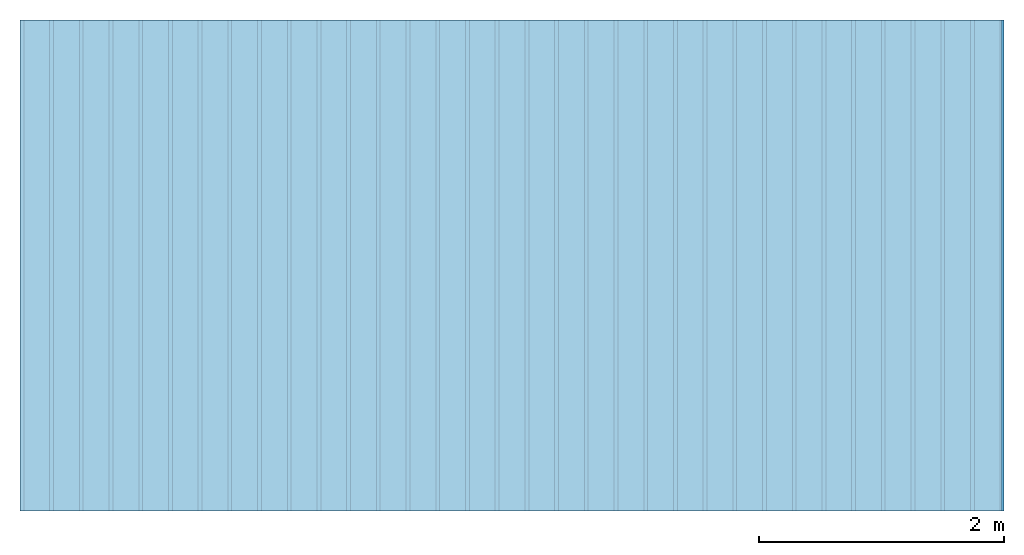
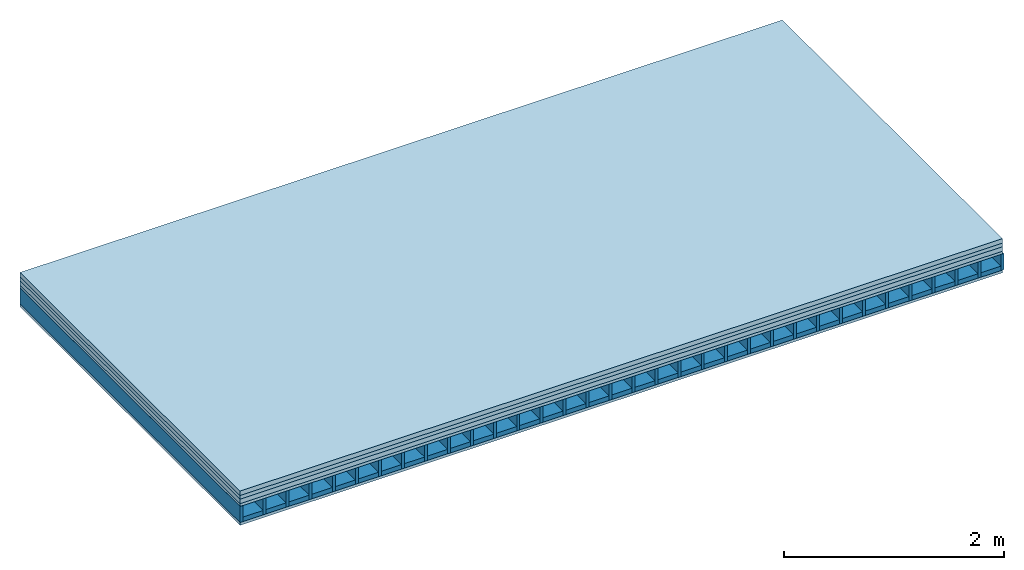
# One storey: 5 plates, 2 members, 1 element without a shape of its own.
"""IFC4 building model written with IfcOpenShell, lengths in metres."""

from ifc_helpers import new_model, si_unit, derived_unit, direction, frame, frame_2d, origin, origin_with_axes, place, context, project, spatial, rectangle, extrude, material, layer, layer_set, type_object, element, aggregate, save


model = new_model("IFC4")

# Units and contexts
plan_context = context("Plan", 3, precision=1e-05, world=origin(), true_north=direction((0.0, 1.0)))
model_context = context("Model", 3, precision=1e-05, world=origin(), true_north=direction((0.0, 1.0)))
ifc_project = project(units=[si_unit("LENGTHUNIT", "METRE"), derived_unit("SOUNDPRESSUREUNIT", [(si_unit("PRESSUREUNIT", "PASCAL", prefix="MICRO"), 0)]), si_unit("ENERGYUNIT", "JOULE", prefix="MEGA"), si_unit("MASSUNIT", "GRAM", prefix="KILO"), derived_unit("THERMALTRANSMITTANCEUNIT", [(si_unit("POWERUNIT", "WATT"), 1), (si_unit("AREAUNIT", "SQUARE_METRE"), -1), (si_unit("THERMODYNAMICTEMPERATUREUNIT", "KELVIN"), -1)]), derived_unit("AREADENSITYUNIT", [(si_unit("MASSUNIT", "GRAM", prefix="KILO"), 1), (si_unit("AREAUNIT", "SQUARE_METRE"), -1)]), derived_unit("USERDEFINED", [(si_unit("ENERGYUNIT", "JOULE", prefix="MEGA"), 1), (si_unit("AREAUNIT", "SQUARE_METRE"), -1)])], contexts=[plan_context, model_context])

# Site, building, storey
site = spatial("IfcSite", under=ifc_project)
building_placement = place(None, origin())
building = spatial("IfcBuilding", under=site, at=building_placement)
storey_placement = place(building_placement, origin())
storey = spatial("IfcBuildingStorey", under=building, at=storey_placement)

# Slab, members, plates
ifc_material_1 = material(Name="Cement screed", Category="04.006")
ifc_layer_1 = layer(ifc_material_1, 0.05, Name="On-material")
ifc_material_2 = material(Name="EP1, 40/35mm")
ifc_layer_2 = layer(ifc_material_2, 0.04, Name="Impact sound insulation")
ifc_material_3 = material(Name="Garden plates", Category="02.007")
ifc_layer_3 = layer(ifc_material_3, 0.05, Name="on Supporting structure")
ifc_material_4 = material(Name="surface element sheathing above")
ifc_layer_4 = layer(ifc_material_4, 0.031, Name="Sub-floor")
ifc_layer_5 = layer(None, 0.178, Name="Supporting structure")
ifc_material_5 = material(Name="surface element sheathing below")
ifc_layer_6 = layer(ifc_material_5, 0.031, Name="Lower layer 1")
ifc_layer_set = layer_set([ifc_layer_1, ifc_layer_2, ifc_layer_3, ifc_layer_4, ifc_layer_5, ifc_layer_6])
slab_type = type_object("IfcSlabType", Name="A2703", PredefinedType="NOTDEFINED", material=ifc_layer_set)
slab_placement = place(None, frame((0.0, 0.0, 0.0), z_axis=(0.0, 0.0, -1.0), x_axis=(1.0, 0.0, 0.0)))
slab = element("IfcSlab", 1, at=slab_placement, inside=storey, type_object=slab_type, material=ifc_layer_set, Name="Slab #1")
ifc_material_6 = material(Name="surface element LFE")
member_1_placement = place(slab_placement, origin())
member_1 = element("IfcMember", 2, at=member_1_placement, material=ifc_material_6, Name="Supporting structure", context=plan_context, shape_type="SweptSolid", body=[
    extrude(rectangle(XDim=0.031, YDim=0.178, at=frame_2d((0.0155, 0.089), x_axis=(1.0, 0.0))), frame((0.0, 4.0, 0.171), z_axis=(0.0, -1.0, 0.0), x_axis=(1.0, 0.0, 0.0)), (0.0, 0.0, 1.0), 4.0),
    extrude(rectangle(XDim=0.031, YDim=0.178, at=frame_2d((0.0155, 0.089), x_axis=(1.0, 0.0))), frame((0.242, 4.0, 0.171), z_axis=(0.0, -1.0, 0.0), x_axis=(1.0, 0.0, 0.0)), (0.0, 0.0, 1.0), 4.0),
    extrude(rectangle(XDim=0.031, YDim=0.178, at=frame_2d((0.0155, 0.089), x_axis=(1.0, 0.0))), frame((0.484, 4.0, 0.171), z_axis=(0.0, -1.0, 0.0), x_axis=(1.0, 0.0, 0.0)), (0.0, 0.0, 1.0), 4.0),
    extrude(rectangle(XDim=0.031, YDim=0.178, at=frame_2d((0.0155, 0.089), x_axis=(1.0, 0.0))), frame((0.726, 4.0, 0.171), z_axis=(0.0, -1.0, 0.0), x_axis=(1.0, 0.0, 0.0)), (0.0, 0.0, 1.0), 4.0),
    extrude(rectangle(XDim=0.031, YDim=0.178, at=frame_2d((0.0155, 0.089), x_axis=(1.0, 0.0))), frame((0.968, 4.0, 0.171), z_axis=(0.0, -1.0, 0.0), x_axis=(1.0, 0.0, 0.0)), (0.0, 0.0, 1.0), 4.0),
    extrude(rectangle(XDim=0.031, YDim=0.178, at=frame_2d((0.0155, 0.089), x_axis=(1.0, 0.0))), frame((1.21, 4.0, 0.171), z_axis=(0.0, -1.0, 0.0), x_axis=(1.0, 0.0, 0.0)), (0.0, 0.0, 1.0), 4.0),
    extrude(rectangle(XDim=0.031, YDim=0.178, at=frame_2d((0.0155, 0.089), x_axis=(1.0, 0.0))), frame((1.452, 4.0, 0.171), z_axis=(0.0, -1.0, 0.0), x_axis=(1.0, 0.0, 0.0)), (0.0, 0.0, 1.0), 4.0),
    extrude(rectangle(XDim=0.031, YDim=0.178, at=frame_2d((0.0155, 0.089), x_axis=(1.0, 0.0))), frame((1.694, 4.0, 0.171), z_axis=(0.0, -1.0, 0.0), x_axis=(1.0, 0.0, 0.0)), (0.0, 0.0, 1.0), 4.0),
    extrude(rectangle(XDim=0.031, YDim=0.178, at=frame_2d((0.0155, 0.089), x_axis=(1.0, 0.0))), frame((1.936, 4.0, 0.171), z_axis=(0.0, -1.0, 0.0), x_axis=(1.0, 0.0, 0.0)), (0.0, 0.0, 1.0), 4.0),
    extrude(rectangle(XDim=0.031, YDim=0.178, at=frame_2d((0.0155, 0.089), x_axis=(1.0, 0.0))), frame((2.178, 4.0, 0.171), z_axis=(0.0, -1.0, 0.0), x_axis=(1.0, 0.0, 0.0)), (0.0, 0.0, 1.0), 4.0),
    extrude(rectangle(XDim=0.031, YDim=0.178, at=frame_2d((0.0155, 0.089), x_axis=(1.0, 0.0))), frame((2.42, 4.0, 0.171), z_axis=(0.0, -1.0, 0.0), x_axis=(1.0, 0.0, 0.0)), (0.0, 0.0, 1.0), 4.0),
    extrude(rectangle(XDim=0.031, YDim=0.178, at=frame_2d((0.0155, 0.089), x_axis=(1.0, 0.0))), frame((2.662, 4.0, 0.171), z_axis=(0.0, -1.0, 0.0), x_axis=(1.0, 0.0, 0.0)), (0.0, 0.0, 1.0), 4.0),
    extrude(rectangle(XDim=0.031, YDim=0.178, at=frame_2d((0.0155, 0.089), x_axis=(1.0, 0.0))), frame((2.904, 4.0, 0.171), z_axis=(0.0, -1.0, 0.0), x_axis=(1.0, 0.0, 0.0)), (0.0, 0.0, 1.0), 4.0),
    extrude(rectangle(XDim=0.031, YDim=0.178, at=frame_2d((0.0155, 0.089), x_axis=(1.0, 0.0))), frame((3.146, 4.0, 0.171), z_axis=(0.0, -1.0, 0.0), x_axis=(1.0, 0.0, 0.0)), (0.0, 0.0, 1.0), 4.0),
    extrude(rectangle(XDim=0.031, YDim=0.178, at=frame_2d((0.0155, 0.089), x_axis=(1.0, 0.0))), frame((3.388, 4.0, 0.171), z_axis=(0.0, -1.0, 0.0), x_axis=(1.0, 0.0, 0.0)), (0.0, 0.0, 1.0), 4.0),
    extrude(rectangle(XDim=0.031, YDim=0.178, at=frame_2d((0.0155, 0.089), x_axis=(1.0, 0.0))), frame((3.63, 4.0, 0.171), z_axis=(0.0, -1.0, 0.0), x_axis=(1.0, 0.0, 0.0)), (0.0, 0.0, 1.0), 4.0),
    extrude(rectangle(XDim=0.031, YDim=0.178, at=frame_2d((0.0155, 0.089), x_axis=(1.0, 0.0))), frame((3.872, 4.0, 0.171), z_axis=(0.0, -1.0, 0.0), x_axis=(1.0, 0.0, 0.0)), (0.0, 0.0, 1.0), 4.0),
    extrude(rectangle(XDim=0.031, YDim=0.178, at=frame_2d((0.0155, 0.089), x_axis=(1.0, 0.0))), frame((4.114, 4.0, 0.171), z_axis=(0.0, -1.0, 0.0), x_axis=(1.0, 0.0, 0.0)), (0.0, 0.0, 1.0), 4.0),
    extrude(rectangle(XDim=0.031, YDim=0.178, at=frame_2d((0.0155, 0.089), x_axis=(1.0, 0.0))), frame((4.356, 4.0, 0.171), z_axis=(0.0, -1.0, 0.0), x_axis=(1.0, 0.0, 0.0)), (0.0, 0.0, 1.0), 4.0),
    extrude(rectangle(XDim=0.031, YDim=0.178, at=frame_2d((0.0155, 0.089), x_axis=(1.0, 0.0))), frame((4.598, 4.0, 0.171), z_axis=(0.0, -1.0, 0.0), x_axis=(1.0, 0.0, 0.0)), (0.0, 0.0, 1.0), 4.0),
    extrude(rectangle(XDim=0.031, YDim=0.178, at=frame_2d((0.0155, 0.089), x_axis=(1.0, 0.0))), frame((4.84, 4.0, 0.171), z_axis=(0.0, -1.0, 0.0), x_axis=(1.0, 0.0, 0.0)), (0.0, 0.0, 1.0), 4.0),
    extrude(rectangle(XDim=0.031, YDim=0.178, at=frame_2d((0.0155, 0.089), x_axis=(1.0, 0.0))), frame((5.082, 4.0, 0.171), z_axis=(0.0, -1.0, 0.0), x_axis=(1.0, 0.0, 0.0)), (0.0, 0.0, 1.0), 4.0),
    extrude(rectangle(XDim=0.031, YDim=0.178, at=frame_2d((0.0155, 0.089), x_axis=(1.0, 0.0))), frame((5.324, 4.0, 0.171), z_axis=(0.0, -1.0, 0.0), x_axis=(1.0, 0.0, 0.0)), (0.0, 0.0, 1.0), 4.0),
    extrude(rectangle(XDim=0.031, YDim=0.178, at=frame_2d((0.0155, 0.089), x_axis=(1.0, 0.0))), frame((5.566, 4.0, 0.171), z_axis=(0.0, -1.0, 0.0), x_axis=(1.0, 0.0, 0.0)), (0.0, 0.0, 1.0), 4.0),
    extrude(rectangle(XDim=0.031, YDim=0.178, at=frame_2d((0.0155, 0.089), x_axis=(1.0, 0.0))), frame((5.808, 4.0, 0.171), z_axis=(0.0, -1.0, 0.0), x_axis=(1.0, 0.0, 0.0)), (0.0, 0.0, 1.0), 4.0),
    extrude(rectangle(XDim=0.031, YDim=0.178, at=frame_2d((0.0155, 0.089), x_axis=(1.0, 0.0))), frame((6.05, 4.0, 0.171), z_axis=(0.0, -1.0, 0.0), x_axis=(1.0, 0.0, 0.0)), (0.0, 0.0, 1.0), 4.0),
    extrude(rectangle(XDim=0.031, YDim=0.178, at=frame_2d((0.0155, 0.089), x_axis=(1.0, 0.0))), frame((6.292, 4.0, 0.171), z_axis=(0.0, -1.0, 0.0), x_axis=(1.0, 0.0, 0.0)), (0.0, 0.0, 1.0), 4.0),
    extrude(rectangle(XDim=0.031, YDim=0.178, at=frame_2d((0.0155, 0.089), x_axis=(1.0, 0.0))), frame((6.534, 4.0, 0.171), z_axis=(0.0, -1.0, 0.0), x_axis=(1.0, 0.0, 0.0)), (0.0, 0.0, 1.0), 4.0),
    extrude(rectangle(XDim=0.031, YDim=0.178, at=frame_2d((0.0155, 0.089), x_axis=(1.0, 0.0))), frame((6.776, 4.0, 0.171), z_axis=(0.0, -1.0, 0.0), x_axis=(1.0, 0.0, 0.0)), (0.0, 0.0, 1.0), 4.0),
    extrude(rectangle(XDim=0.031, YDim=0.178, at=frame_2d((0.0155, 0.089), x_axis=(1.0, 0.0))), frame((7.018, 4.0, 0.171), z_axis=(0.0, -1.0, 0.0), x_axis=(1.0, 0.0, 0.0)), (0.0, 0.0, 1.0), 4.0),
    extrude(rectangle(XDim=0.031, YDim=0.178, at=frame_2d((0.0155, 0.089), x_axis=(1.0, 0.0))), frame((7.26, 4.0, 0.171), z_axis=(0.0, -1.0, 0.0), x_axis=(1.0, 0.0, 0.0)), (0.0, 0.0, 1.0), 4.0),
    extrude(rectangle(XDim=0.031, YDim=0.178, at=frame_2d((0.0155, 0.089), x_axis=(1.0, 0.0))), frame((7.502, 4.0, 0.171), z_axis=(0.0, -1.0, 0.0), x_axis=(1.0, 0.0, 0.0)), (0.0, 0.0, 1.0), 4.0),
    extrude(rectangle(XDim=0.031, YDim=0.178, at=frame_2d((0.0155, 0.089), x_axis=(1.0, 0.0))), frame((7.744, 4.0, 0.171), z_axis=(0.0, -1.0, 0.0), x_axis=(1.0, 0.0, 0.0)), (0.0, 0.0, 1.0), 4.0),
    extrude(rectangle(XDim=0.031, YDim=0.178, at=frame_2d((0.0155, 0.089), x_axis=(1.0, 0.0))), frame((7.986, 4.0, 0.171), z_axis=(0.0, -1.0, 0.0), x_axis=(1.0, 0.0, 0.0)), (0.0, 0.0, 1.0), 4.0),
])
ifc_material_7 = material()
member_2_placement = place(slab_placement, origin())
member_2 = element("IfcMember", 3, at=member_2_placement, material=ifc_material_7, Name="in supporting structure", context=plan_context, shape_type="SweptSolid", body=[
    extrude(rectangle(XDim=0.211, YDim=0.049, at=frame_2d((0.1055, 0.0245), x_axis=(1.0, 0.0))), frame((0.031, 4.0, 0.3), z_axis=(0.0, -1.0, 0.0), x_axis=(1.0, 0.0, 0.0)), (0.0, 0.0, 1.0), 4.0),
    extrude(rectangle(XDim=0.211, YDim=0.049, at=frame_2d((0.1055, 0.0245), x_axis=(1.0, 0.0))), frame((0.273, 4.0, 0.3), z_axis=(0.0, -1.0, 0.0), x_axis=(1.0, 0.0, 0.0)), (0.0, 0.0, 1.0), 4.0),
    extrude(rectangle(XDim=0.211, YDim=0.049, at=frame_2d((0.1055, 0.0245), x_axis=(1.0, 0.0))), frame((0.515, 4.0, 0.3), z_axis=(0.0, -1.0, 0.0), x_axis=(1.0, 0.0, 0.0)), (0.0, 0.0, 1.0), 4.0),
    extrude(rectangle(XDim=0.211, YDim=0.049, at=frame_2d((0.1055, 0.0245), x_axis=(1.0, 0.0))), frame((0.757, 4.0, 0.3), z_axis=(0.0, -1.0, 0.0), x_axis=(1.0, 0.0, 0.0)), (0.0, 0.0, 1.0), 4.0),
    extrude(rectangle(XDim=0.211, YDim=0.049, at=frame_2d((0.1055, 0.0245), x_axis=(1.0, 0.0))), frame((0.999, 4.0, 0.3), z_axis=(0.0, -1.0, 0.0), x_axis=(1.0, 0.0, 0.0)), (0.0, 0.0, 1.0), 4.0),
    extrude(rectangle(XDim=0.211, YDim=0.049, at=frame_2d((0.1055, 0.0245), x_axis=(1.0, 0.0))), frame((1.241, 4.0, 0.3), z_axis=(0.0, -1.0, 0.0), x_axis=(1.0, 0.0, 0.0)), (0.0, 0.0, 1.0), 4.0),
    extrude(rectangle(XDim=0.211, YDim=0.049, at=frame_2d((0.1055, 0.0245), x_axis=(1.0, 0.0))), frame((1.483, 4.0, 0.3), z_axis=(0.0, -1.0, 0.0), x_axis=(1.0, 0.0, 0.0)), (0.0, 0.0, 1.0), 4.0),
    extrude(rectangle(XDim=0.211, YDim=0.049, at=frame_2d((0.1055, 0.0245), x_axis=(1.0, 0.0))), frame((1.725, 4.0, 0.3), z_axis=(0.0, -1.0, 0.0), x_axis=(1.0, 0.0, 0.0)), (0.0, 0.0, 1.0), 4.0),
    extrude(rectangle(XDim=0.211, YDim=0.049, at=frame_2d((0.1055, 0.0245), x_axis=(1.0, 0.0))), frame((1.967, 4.0, 0.3), z_axis=(0.0, -1.0, 0.0), x_axis=(1.0, 0.0, 0.0)), (0.0, 0.0, 1.0), 4.0),
    extrude(rectangle(XDim=0.211, YDim=0.049, at=frame_2d((0.1055, 0.0245), x_axis=(1.0, 0.0))), frame((2.209, 4.0, 0.3), z_axis=(0.0, -1.0, 0.0), x_axis=(1.0, 0.0, 0.0)), (0.0, 0.0, 1.0), 4.0),
    extrude(rectangle(XDim=0.211, YDim=0.049, at=frame_2d((0.1055, 0.0245), x_axis=(1.0, 0.0))), frame((2.451, 4.0, 0.3), z_axis=(0.0, -1.0, 0.0), x_axis=(1.0, 0.0, 0.0)), (0.0, 0.0, 1.0), 4.0),
    extrude(rectangle(XDim=0.211, YDim=0.049, at=frame_2d((0.1055, 0.0245), x_axis=(1.0, 0.0))), frame((2.693, 4.0, 0.3), z_axis=(0.0, -1.0, 0.0), x_axis=(1.0, 0.0, 0.0)), (0.0, 0.0, 1.0), 4.0),
    extrude(rectangle(XDim=0.211, YDim=0.049, at=frame_2d((0.1055, 0.0245), x_axis=(1.0, 0.0))), frame((2.935, 4.0, 0.3), z_axis=(0.0, -1.0, 0.0), x_axis=(1.0, 0.0, 0.0)), (0.0, 0.0, 1.0), 4.0),
    extrude(rectangle(XDim=0.211, YDim=0.049, at=frame_2d((0.1055, 0.0245), x_axis=(1.0, 0.0))), frame((3.177, 4.0, 0.3), z_axis=(0.0, -1.0, 0.0), x_axis=(1.0, 0.0, 0.0)), (0.0, 0.0, 1.0), 4.0),
    extrude(rectangle(XDim=0.211, YDim=0.049, at=frame_2d((0.1055, 0.0245), x_axis=(1.0, 0.0))), frame((3.419, 4.0, 0.3), z_axis=(0.0, -1.0, 0.0), x_axis=(1.0, 0.0, 0.0)), (0.0, 0.0, 1.0), 4.0),
    extrude(rectangle(XDim=0.211, YDim=0.049, at=frame_2d((0.1055, 0.0245), x_axis=(1.0, 0.0))), frame((3.661, 4.0, 0.3), z_axis=(0.0, -1.0, 0.0), x_axis=(1.0, 0.0, 0.0)), (0.0, 0.0, 1.0), 4.0),
    extrude(rectangle(XDim=0.211, YDim=0.049, at=frame_2d((0.1055, 0.0245), x_axis=(1.0, 0.0))), frame((3.903, 4.0, 0.3), z_axis=(0.0, -1.0, 0.0), x_axis=(1.0, 0.0, 0.0)), (0.0, 0.0, 1.0), 4.0),
    extrude(rectangle(XDim=0.211, YDim=0.049, at=frame_2d((0.1055, 0.0245), x_axis=(1.0, 0.0))), frame((4.145, 4.0, 0.3), z_axis=(0.0, -1.0, 0.0), x_axis=(1.0, 0.0, 0.0)), (0.0, 0.0, 1.0), 4.0),
    extrude(rectangle(XDim=0.211, YDim=0.049, at=frame_2d((0.1055, 0.0245), x_axis=(1.0, 0.0))), frame((4.387, 4.0, 0.3), z_axis=(0.0, -1.0, 0.0), x_axis=(1.0, 0.0, 0.0)), (0.0, 0.0, 1.0), 4.0),
    extrude(rectangle(XDim=0.211, YDim=0.049, at=frame_2d((0.1055, 0.0245), x_axis=(1.0, 0.0))), frame((4.629, 4.0, 0.3), z_axis=(0.0, -1.0, 0.0), x_axis=(1.0, 0.0, 0.0)), (0.0, 0.0, 1.0), 4.0),
    extrude(rectangle(XDim=0.211, YDim=0.049, at=frame_2d((0.1055, 0.0245), x_axis=(1.0, 0.0))), frame((4.871, 4.0, 0.3), z_axis=(0.0, -1.0, 0.0), x_axis=(1.0, 0.0, 0.0)), (0.0, 0.0, 1.0), 4.0),
    extrude(rectangle(XDim=0.211, YDim=0.049, at=frame_2d((0.1055, 0.0245), x_axis=(1.0, 0.0))), frame((5.113, 4.0, 0.3), z_axis=(0.0, -1.0, 0.0), x_axis=(1.0, 0.0, 0.0)), (0.0, 0.0, 1.0), 4.0),
    extrude(rectangle(XDim=0.211, YDim=0.049, at=frame_2d((0.1055, 0.0245), x_axis=(1.0, 0.0))), frame((5.355, 4.0, 0.3), z_axis=(0.0, -1.0, 0.0), x_axis=(1.0, 0.0, 0.0)), (0.0, 0.0, 1.0), 4.0),
    extrude(rectangle(XDim=0.211, YDim=0.049, at=frame_2d((0.1055, 0.0245), x_axis=(1.0, 0.0))), frame((5.597, 4.0, 0.3), z_axis=(0.0, -1.0, 0.0), x_axis=(1.0, 0.0, 0.0)), (0.0, 0.0, 1.0), 4.0),
    extrude(rectangle(XDim=0.211, YDim=0.049, at=frame_2d((0.1055, 0.0245), x_axis=(1.0, 0.0))), frame((5.839, 4.0, 0.3), z_axis=(0.0, -1.0, 0.0), x_axis=(1.0, 0.0, 0.0)), (0.0, 0.0, 1.0), 4.0),
    extrude(rectangle(XDim=0.211, YDim=0.049, at=frame_2d((0.1055, 0.0245), x_axis=(1.0, 0.0))), frame((6.081, 4.0, 0.3), z_axis=(0.0, -1.0, 0.0), x_axis=(1.0, 0.0, 0.0)), (0.0, 0.0, 1.0), 4.0),
    extrude(rectangle(XDim=0.211, YDim=0.049, at=frame_2d((0.1055, 0.0245), x_axis=(1.0, 0.0))), frame((6.323, 4.0, 0.3), z_axis=(0.0, -1.0, 0.0), x_axis=(1.0, 0.0, 0.0)), (0.0, 0.0, 1.0), 4.0),
    extrude(rectangle(XDim=0.211, YDim=0.049, at=frame_2d((0.1055, 0.0245), x_axis=(1.0, 0.0))), frame((6.565, 4.0, 0.3), z_axis=(0.0, -1.0, 0.0), x_axis=(1.0, 0.0, 0.0)), (0.0, 0.0, 1.0), 4.0),
    extrude(rectangle(XDim=0.211, YDim=0.049, at=frame_2d((0.1055, 0.0245), x_axis=(1.0, 0.0))), frame((6.807, 4.0, 0.3), z_axis=(0.0, -1.0, 0.0), x_axis=(1.0, 0.0, 0.0)), (0.0, 0.0, 1.0), 4.0),
    extrude(rectangle(XDim=0.211, YDim=0.049, at=frame_2d((0.1055, 0.0245), x_axis=(1.0, 0.0))), frame((7.049, 4.0, 0.3), z_axis=(0.0, -1.0, 0.0), x_axis=(1.0, 0.0, 0.0)), (0.0, 0.0, 1.0), 4.0),
    extrude(rectangle(XDim=0.211, YDim=0.049, at=frame_2d((0.1055, 0.0245), x_axis=(1.0, 0.0))), frame((7.291, 4.0, 0.3), z_axis=(0.0, -1.0, 0.0), x_axis=(1.0, 0.0, 0.0)), (0.0, 0.0, 1.0), 4.0),
    extrude(rectangle(XDim=0.211, YDim=0.049, at=frame_2d((0.1055, 0.0245), x_axis=(1.0, 0.0))), frame((7.533, 4.0, 0.3), z_axis=(0.0, -1.0, 0.0), x_axis=(1.0, 0.0, 0.0)), (0.0, 0.0, 1.0), 4.0),
    extrude(rectangle(XDim=0.211, YDim=0.049, at=frame_2d((0.1055, 0.0245), x_axis=(1.0, 0.0))), frame((7.775, 4.0, 0.3), z_axis=(0.0, -1.0, 0.0), x_axis=(1.0, 0.0, 0.0)), (0.0, 0.0, 1.0), 4.0),
])
plate_1_placement = place(slab_placement, origin())
plate_1 = element("IfcPlate", 4, at=plate_1_placement, material=ifc_material_1, Name="On-material", context=plan_context, shape_type="SweptSolid", body=[
    extrude(rectangle(XDim=8.0, YDim=4.0, at=frame_2d((4.0, 2.0), x_axis=(1.0, 0.0))), origin_with_axes(), (0.0, 0.0, 1.0), 0.05),
])
plate_2_placement = place(slab_placement, origin())
plate_2 = element("IfcPlate", 5, at=plate_2_placement, material=ifc_material_2, Name="Impact sound insulation", context=plan_context, shape_type="SweptSolid", body=[
    extrude(rectangle(XDim=8.0, YDim=4.0, at=frame_2d((4.0, 2.0), x_axis=(1.0, 0.0))), frame((0.0, 0.0, 0.05), z_axis=(0.0, 0.0, 1.0), x_axis=(1.0, 0.0, 0.0)), (0.0, 0.0, 1.0), 0.04),
])
plate_3_placement = place(slab_placement, origin())
plate_3 = element("IfcPlate", 6, at=plate_3_placement, material=ifc_material_3, Name="on Supporting structure", context=plan_context, shape_type="SweptSolid", body=[
    extrude(rectangle(XDim=8.0, YDim=4.0, at=frame_2d((4.0, 2.0), x_axis=(1.0, 0.0))), frame((0.0, 0.0, 0.09), z_axis=(0.0, 0.0, 1.0), x_axis=(1.0, 0.0, 0.0)), (0.0, 0.0, 1.0), 0.05),
])
plate_4_placement = place(slab_placement, origin())
plate_4 = element("IfcPlate", 7, at=plate_4_placement, material=ifc_material_4, Name="Sub-floor", context=plan_context, shape_type="SweptSolid", body=[
    extrude(rectangle(XDim=8.0, YDim=4.0, at=frame_2d((4.0, 2.0), x_axis=(1.0, 0.0))), frame((0.0, 0.0, 0.14), z_axis=(0.0, 0.0, 1.0), x_axis=(1.0, 0.0, 0.0)), (0.0, 0.0, 1.0), 0.031),
])
plate_5_placement = place(slab_placement, origin())
plate_5 = element("IfcPlate", 8, at=plate_5_placement, material=ifc_material_5, Name="Lower layer 1", context=plan_context, shape_type="SweptSolid", body=[
    extrude(rectangle(XDim=8.0, YDim=4.0, at=frame_2d((4.0, 2.0), x_axis=(1.0, 0.0))), frame((0.0, 0.0, 0.349), z_axis=(0.0, 0.0, 1.0), x_axis=(1.0, 0.0, 0.0)), (0.0, 0.0, 1.0), 0.031),
])
aggregate(slab, [plate_1, plate_2, plate_3, plate_4, member_1, member_2, plate_5])

save(model, "model.ifc")
